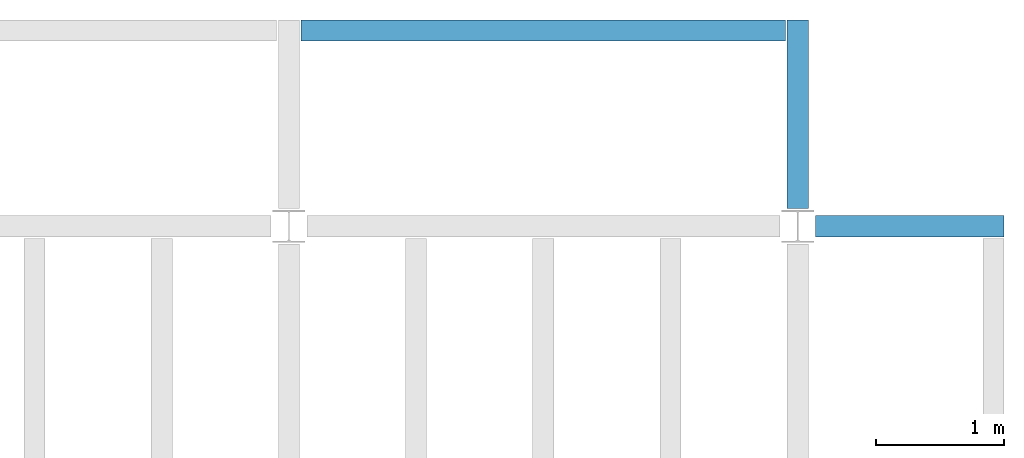
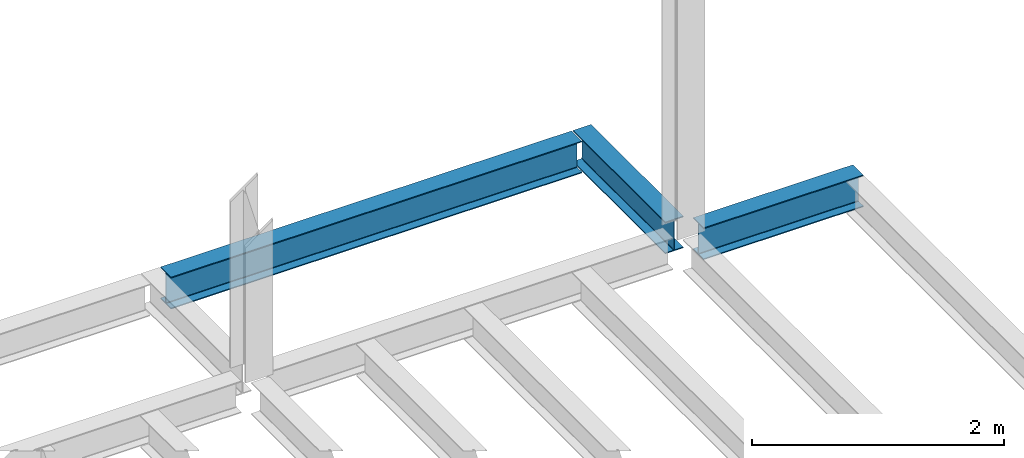
# One storey, part 3 of 3: 3 beams.
"""IFC4 building model written with IfcOpenShell, lengths in feet."""

import ifcopenshell
import ifcopenshell.guid

model = None  # the IFC model being written
_history = None  # IfcOwnerHistory: only IFC2X3 demands one
_inside = {}  # id of a spatial element -> (the spatial element, [elements in it])
_under = {}  # id of a project, library or spatial element -> (it, [spatial elements below it])
_declared = {}  # id of a project -> (the project, [libraries it declares])
_typed = {}  # id of a type object -> (the type object, [elements of that type])
_made_of = {}  # id of a material, layer set ... -> (it, [elements and type objects made of it])


def new_model(schema):
    """Start an empty IFC model of exactly this schema.

    Asked for "IFC4X3", IfcOpenShell would pick the latest addendum, in which some entities
    have other attributes; the version numbers below select the first issue.
    IFC2X3 requires an IfcOwnerHistory on every rooted entity: one is made here for all.
    """
    global model, _history
    if schema == "IFC4X3":
        model = ifcopenshell.file(schema_version=(4, 3, 0, 0))
    else:
        model = ifcopenshell.file(schema=schema)
    _inside.clear()
    _under.clear()
    _declared.clear()
    _typed.clear()
    _made_of.clear()
    _history = None
    if model.schema == "IFC2X3":
        org = make("IfcOrganization", Name="unknown")
        user = make(
            "IfcPersonAndOrganization",
            ThePerson=make("IfcPerson", FamilyName="unknown"),
            TheOrganization=org,
        )
        app = make(
            "IfcApplication",
            ApplicationDeveloper=org,
            Version="unknown",
            ApplicationFullName="unknown",
            ApplicationIdentifier="unknown",
        )
        _history = make(
            "IfcOwnerHistory",
            OwningUser=user,
            OwningApplication=app,
            ChangeAction="ADDED",
            CreationDate=0,
        )
    return model


def make(cls, **values):
    """One entity of the class cls with the attributes given. An attribute that is None is left unset."""
    return model.create_entity(
        cls, **{name: value for name, value in values.items() if value is not None}
    )


def entity(cls, *values):
    """Any entity or typed value of the class cls, its attributes in the order of the schema. None: left unset."""
    e = model.create_entity(cls)
    for i, value in enumerate(values):
        if value is not None:
            e[i] = value
    return e


def rooted(cls, **values):
    """An entity with a GlobalId (a new one), such as an element, a storey or a relation."""
    return make(cls, GlobalId=ifcopenshell.guid.new(), OwnerHistory=_history, **values)


def si_unit(unit_type, name, prefix=None):
    """IfcSIUnit, for example si_unit("LENGTHUNIT", "METRE", prefix="MILLI")."""
    return make("IfcSIUnit", UnitType=unit_type, Prefix=prefix, Name=name)


def converted_unit(unit_type, name, factor, base, dimensions=None, offset=None):
    """IfcConversionBasedUnit, such as the inch: factor (a typed value) times the base unit."""
    return make(
        "IfcConversionBasedUnit"
        if offset is None
        else "IfcConversionBasedUnitWithOffset",
        ConversionOffset=offset,
        Dimensions=None
        if dimensions is None
        else entity("IfcDimensionalExponents", *dimensions),
        UnitType=unit_type,
        Name=name,
        ConversionFactor=make(
            "IfcMeasureWithUnit", ValueComponent=factor, UnitComponent=base
        ),
    )


def derived_unit(unit_type, elements):
    """IfcDerivedUnit: a product of units, each with its exponent."""
    return make(
        "IfcDerivedUnit",
        Elements=[
            make("IfcDerivedUnitElement", Unit=unit, Exponent=power)
            for unit, power in elements
        ],
        UnitType=unit_type,
    )


def assignment(units):
    """IfcUnitAssignment: the units of a project."""
    return None if units is None else make("IfcUnitAssignment", Units=units)


def point(xyz):
    """IfcCartesianPoint."""
    return None if xyz is None else make("IfcCartesianPoint", Coordinates=xyz)


def direction(xyz):
    """IfcDirection."""
    return None if xyz is None else make("IfcDirection", DirectionRatios=xyz)


def frame(location, z_axis=None, x_axis=None):
    """IfcAxis2Placement3D, a coordinate frame: its origin and axes. An axis left out is left unset."""
    return make(
        "IfcAxis2Placement3D",
        Location=point(location),
        Axis=direction(z_axis),
        RefDirection=direction(x_axis),
    )


def origin():
    """The frame at (0, 0, 0) with its axes left unset."""
    return frame((0.0, 0.0, 0.0))


def place(relative_to, where):
    """IfcLocalPlacement: puts the frame where relative to a parent placement (None: the world)."""
    return make(
        "IfcLocalPlacement", PlacementRelTo=relative_to, RelativePlacement=where
    )


def context(
    kind, dimensions, precision=None, world=None, true_north=None, identifier=None
):
    """IfcGeometricRepresentationContext, for example the 3D "Model" context."""
    return make(
        "IfcGeometricRepresentationContext",
        ContextIdentifier=identifier,
        ContextType=kind,
        CoordinateSpaceDimension=dimensions,
        Precision=precision,
        WorldCoordinateSystem=world,
        TrueNorth=true_north,
    )


def subcontext(parent, identifier, kind, view, scale=None):
    """IfcGeometricRepresentationSubContext, for example "Body" below "Model"."""
    return make(
        "IfcGeometricRepresentationSubContext",
        ContextIdentifier=identifier,
        ContextType=kind,
        ParentContext=parent,
        TargetScale=scale,
        TargetView=view,
    )


def project(units=None, contexts=None):
    """IfcProject with its units and contexts."""
    return rooted(
        "IfcProject",
        Name="project",
        RepresentationContexts=contexts,
        UnitsInContext=assignment(units),
    )


def spatial(cls, under=None, at=None, **own):
    """A site, building, storey or space (cls), placed at a placement, below another one or the project."""
    s = rooted(cls, ObjectPlacement=at, **own)
    if under is not None:
        _under.setdefault(under.id(), (under, []))[1].append(s)
    return s


def point_list(points):
    """IfcCartesianPointList2D or 3D."""
    cls = (
        "IfcCartesianPointList2D" if len(points[0]) == 2 else "IfcCartesianPointList3D"
    )
    return make(cls, CoordList=points)


def line(*indices):
    """IfcLineIndex: a straight run through numbered points of an indexed curve."""
    return model.create_entity("IfcLineIndex", indices)


def arc(*indices):
    """IfcArcIndex: an arc through three numbered points of an indexed curve."""
    return model.create_entity("IfcArcIndex", indices)


def indexed_curve(points, segments=None, self_intersect=None):
    """IfcIndexedPolyCurve: lines and arcs through numbered points (the first is 1)."""
    return make(
        "IfcIndexedPolyCurve",
        Points=point_list(points),
        Segments=segments,
        SelfIntersect=self_intersect,
    )


def outline(outer, holes=None, kind="AREA"):
    """IfcArbitraryClosedProfileDef: a profile drawn as a closed curve; with holes, ...WithVoids."""
    if holes is None:
        return make("IfcArbitraryClosedProfileDef", ProfileType=kind, OuterCurve=outer)
    return make(
        "IfcArbitraryProfileDefWithVoids",
        ProfileType=kind,
        OuterCurve=outer,
        InnerCurves=holes,
    )


def extrude(swept, where, along, depth):
    """IfcExtrudedAreaSolid: the profile swept, set in the frame where, extruded along a direction by depth."""
    return make(
        "IfcExtrudedAreaSolid",
        SweptArea=swept,
        Position=where,
        ExtrudedDirection=direction(along),
        Depth=depth,
    )


def shape(context_of_items, identifier, shape_type, items):
    """IfcShapeRepresentation: the items that make up one representation, for example the "Body"."""
    return make(
        "IfcShapeRepresentation",
        ContextOfItems=context_of_items,
        RepresentationIdentifier=identifier,
        RepresentationType=shape_type,
        Items=items,
    )


def source(mapping_origin, context_of_items, identifier, shape_type, items):
    """IfcRepresentationMap: a shape defined once, which mapped items show again and again."""
    return make(
        "IfcRepresentationMap",
        MappingOrigin=mapping_origin,
        MappedRepresentation=shape(context_of_items, identifier, shape_type, items),
    )


def transform(
    local_origin,
    x_axis=None,
    y_axis=None,
    z_axis=None,
    scale=None,
    scale2=None,
    scale3=None,
    uniform=True,
):
    """IfcCartesianTransformationOperator3D, or its non-uniform kind. x_axis, y_axis, z_axis: its Axis1, 2, 3."""
    if uniform:
        return make(
            "IfcCartesianTransformationOperator3D",
            Axis1=direction(x_axis),
            Axis2=direction(y_axis),
            LocalOrigin=point(local_origin),
            Scale=scale,
            Axis3=direction(z_axis),
        )
    return make(
        "IfcCartesianTransformationOperator3DnonUniform",
        Axis1=direction(x_axis),
        Axis2=direction(y_axis),
        LocalOrigin=point(local_origin),
        Scale=scale,
        Axis3=direction(z_axis),
        Scale2=scale2,
        Scale3=scale3,
    )


def mapped(mapping_source, mapping_target):
    """IfcMappedItem: shows the shape of a source again, moved by a transform."""
    return make(
        "IfcMappedItem", MappingSource=mapping_source, MappingTarget=mapping_target
    )


def material(Name=None, Category=None):
    """IfcMaterial."""
    return make("IfcMaterial", Name=Name, Category=Category)


def made_of(thing, what):
    """Note that an element or type object is made of a material, layer set ...; save() writes the relation."""
    if what is not None:
        _made_of.setdefault(what.id(), (what, []))[1].append(thing)
    return thing


def type_object(cls, material=None, **own):
    """A type object (cls), such as IfcWallType, which elements share."""
    return made_of(rooted(cls, **own), material)


def type_shapes(of_type, sources):
    """Give a type object the sources (RepresentationMaps) that its elements show as mapped items."""
    of_type.RepresentationMaps = sources


def element(
    cls,
    number,
    at=None,
    inside=None,
    cuts=None,
    type_object=None,
    material=None,
    context=None,
    identifier="Body",
    shape_type=None,
    held_by="IfcProductDefinitionShape",
    body=None,
    shapes=None,
    **own,
):
    """One element of the class cls, such as IfcWall. Its Tag is "e" and its number.

    at: its placement. inside: the storey or other place that contains it. cuts: it is an
    opening in that element (IfcRelVoidsElement). A single representation is given by context,
    identifier, shape_type and body (its items); several are given by shapes. held_by: the class
    of the entity that holds the representations. save() writes the other relations.
    """
    e = rooted(cls, Tag="e%d" % number, ObjectPlacement=at, **own)
    if body is not None:
        shapes = [shape(context, identifier, shape_type, body)]
    if shapes is not None:
        e.Representation = make(held_by, Representations=shapes)
    if inside is not None:
        _inside.setdefault(inside.id(), (inside, []))[1].append(e)
    if cuts is not None:
        rooted(
            "IfcRelVoidsElement", RelatingBuildingElement=cuts, RelatedOpeningElement=e
        )
    if type_object is not None:
        _typed.setdefault(type_object.id(), (type_object, []))[1].append(e)
    return made_of(e, material)


def aggregate(whole, parts):
    """IfcRelAggregates: a whole, such as a stair, and the parts it consists of."""
    return rooted("IfcRelAggregates", RelatingObject=whole, RelatedObjects=parts)


def save(model, path):
    """Write the relations noted so far, then the file.

    IfcRelAggregates (storeys below a building ...), IfcRelContainedInSpatialStructure (elements
    in a storey), IfcRelDefinesByType, IfcRelAssociatesMaterial and IfcRelDeclares: one each for
    every whole, place, type object, material and project.
    """
    for whole, parts in _under.values():
        aggregate(whole, parts)
    for where, things in _inside.values():
        rooted(
            "IfcRelContainedInSpatialStructure",
            RelatedElements=things,
            RelatingStructure=where,
        )
    for kind, things in _typed.values():
        rooted("IfcRelDefinesByType", RelatedObjects=things, RelatingType=kind)
    for what, things in _made_of.values():
        rooted("IfcRelAssociatesMaterial", RelatedObjects=things, RelatingMaterial=what)
    for by, libraries in _declared.values():
        rooted("IfcRelDeclares", RelatingContext=by, RelatedDefinitions=libraries)
    model.write(path)


model = new_model("IFC4")

# Units and contexts
model_context = context("Model", 3, precision=0.0001, world=origin(), true_north=direction((6.123233995736766e-17, 1.0)))
plan_context = context("Plan", 3, precision=0.0001, world=origin(), true_north=direction((6.123233995736766e-17, 1.0)))
body_context = subcontext(model_context, "Body", "Model", "MODEL_VIEW")
ifc_project = project(units=[converted_unit("LENGTHUNIT", "FOOT", entity("IfcLengthMeasure", 0.3048), si_unit("LENGTHUNIT", "METRE"), dimensions=[1, 0, 0, 0, 0, 0, 0]), converted_unit("AREAUNIT", "SQUARE FOOT", entity("IfcAreaMeasure", 0.09290304), si_unit("AREAUNIT", "SQUARE_METRE"), dimensions=[2, 0, 0, 0, 0, 0, 0]), converted_unit("PLANEANGLEUNIT", "DEGREE", entity("IfcPlaneAngleMeasure", 0.017453292519943278), si_unit("PLANEANGLEUNIT", "RADIAN"), dimensions=[0, 0, 0, 0, 0, 0, 0]), converted_unit("VOLUMEUNIT", "CUBIC FOOT", entity("IfcVolumeMeasure", 0.028316846592000004), si_unit("VOLUMEUNIT", "CUBIC_METRE"), dimensions=[3, 0, 0, 0, 0, 0, 0]), si_unit("PRESSUREUNIT", "PASCAL"), derived_unit("MASSDENSITYUNIT", [(si_unit("MASSUNIT", "GRAM", prefix="KILO"), 1), (si_unit("LENGTHUNIT", "METRE"), -3)]), derived_unit("VAPORPERMEABILITYUNIT", [(si_unit("LENGTHUNIT", "METRE"), -1), (si_unit("TIMEUNIT", "SECOND"), 1)]), derived_unit("USERDEFINED", [(si_unit("MASSUNIT", "GRAM", prefix="KILO"), 1), (si_unit("LENGTHUNIT", "METRE"), 3), (si_unit("TIMEUNIT", "SECOND"), -3), (si_unit("ELECTRICCURRENTUNIT", "AMPERE"), -2)]), derived_unit("MODULUSOFELASTICITYUNIT", [(si_unit("MASSUNIT", "GRAM", prefix="KILO"), 1), (si_unit("LENGTHUNIT", "METRE"), -1), (si_unit("TIMEUNIT", "SECOND"), -2)]), derived_unit("THERMALEXPANSIONCOEFFICIENTUNIT", [(si_unit("THERMODYNAMICTEMPERATUREUNIT", "KELVIN"), -1)]), derived_unit("SPECIFICHEATCAPACITYUNIT", [(si_unit("TIMEUNIT", "SECOND"), -2), (si_unit("THERMODYNAMICTEMPERATUREUNIT", "KELVIN"), -1), (si_unit("LENGTHUNIT", "METRE"), 2)]), derived_unit("THERMALCONDUCTANCEUNIT", [(si_unit("MASSUNIT", "GRAM", prefix="KILO"), 1), (si_unit("TIMEUNIT", "SECOND"), -3), (si_unit("THERMODYNAMICTEMPERATUREUNIT", "KELVIN"), -1), (si_unit("LENGTHUNIT", "METRE"), 1)])], contexts=[model_context, plan_context])

# Site, building, storey
site_placement = place(None, origin())
site = spatial("IfcSite", under=ifc_project, at=site_placement, CompositionType="ELEMENT")
building_placement = place(site_placement, origin())
building = spatial("IfcBuilding", under=site, at=building_placement, CompositionType="ELEMENT")
storey_placement = place(building_placement, frame((0.0, 0.0, 119.875)))
storey = spatial("IfcBuildingStorey", under=building, at=storey_placement, Name="STR 13", CompositionType="ELEMENT", Elevation=119.875)

# Beams
ifc_material = material(Name="Steel ASTM A992", Category="Metal")
beam_type_1 = type_object("IfcBeamType", Name="W12X26", PredefinedType="JOIST", material=ifc_material)
shared_shape_1 = source(origin(), body_context, "Body", "SweptSolid", [
    extrude(outline(indexed_curve([(0.47666666666666574, -0.2704166666666672), (0.5083333333333351, -0.2704166666666672), (0.5083333333333351, 0.27041666666666686), (0.47666666666666574, 0.27041666666666686), (0.47666666666666574, 0.03458333333333307), (0.46934433619632937, 0.016905663803669473), (0.4516666666666659, 0.00958333333333318), (-0.45166666666666705, 0.00958333333333318), (-0.4693443361963307, 0.01690566380366946), (-0.4766666666666671, 0.03458333333333323), (-0.4766666666666671, 0.27041666666666686), (-0.5083333333333312, 0.27041666666666686), (-0.5083333333333312, -0.27041666666666553), (-0.4766666666666671, -0.27041666666666553), (-0.47666666666666707, -0.034583333333333535), (-0.46934433619633054, -0.016905663803669885), (-0.45166666666666694, -0.00958333333333376), (0.4516666666666658, -0.009583333333333756), (0.4693443361963295, -0.01690566380367015), (0.47666666666666574, -0.0345833333333337)], segments=[line(1, 2, 3, 4, 5), arc(5, 6, 7), line(7, 8), arc(8, 9, 10), line(10, 11, 12, 13, 14, 15), arc(15, 16, 17), line(17, 18), arc(18, 19, 20), line(20, 1)], self_intersect=False)), frame((-2.77041666666672, 0.0, 0.0), z_axis=(1.0, 0.0, 0.0), x_axis=(0.0, 0.0, -1.0)), (0.0, 0.0, 1.0), 4.812083333333389),
])
type_shapes(beam_type_1, [shared_shape_1])
beam_1_placement = place(storey_placement, frame((41.50000000000015, 39.0, -0.50833333333334), z_axis=(0.0, 0.0, 1.0), x_axis=(-1.0, 0.0, 0.0)))
element("IfcBeam", 1, at=beam_1_placement, inside=storey, type_object=beam_type_1, material=ifc_material, Name="W12X26", ObjectType="W Shapes:W12X26", PredefinedType="JOIST", context=body_context, shape_type="MappedRepresentation", body=[
    mapped(shared_shape_1, transform((0.0, 0.0, 0.0), scale=1.0)),
])
beam_type_2 = type_object("IfcBeamType", Name="W12X26", PredefinedType="JOIST", material=ifc_material)
shared_shape_2 = source(origin(), body_context, "Body", "SweptSolid", [
    extrude(outline(indexed_curve([(-0.2704166666666623, -0.50833333333334), (0.2704166666666694, -0.50833333333334), (0.2704166666666694, -0.4766666666666737), (0.03458333333333741, -0.4766666666666879), (0.01690566380367642, -0.4693443361963432), (0.009583333333338828, -0.4516666666666822), (0.009583333333338828, 0.4516666666666538), (0.01690566380367642, 0.46934433619631477), (0.03458333333333741, 0.47666666666665947), (0.2704166666666694, 0.47666666666665947), (0.2704166666666694, 0.5083333333333258), (-0.2704166666666623, 0.5083333333333258), (-0.2704166666666623, 0.47666666666665947), (-0.0345833333333303, 0.47666666666665947), (-0.016905663803669313, 0.46934433619631477), (-0.009583333333331723, 0.4516666666666538), (-0.009583333333331723, -0.4516666666666822), (-0.016905663803669313, -0.4693443361963432), (-0.0345833333333303, -0.4766666666666737), (-0.2704166666666623, -0.4766666666666737)], segments=[line(1, 2, 3, 4), arc(4, 5, 6), line(6, 7), arc(7, 8, 9), line(9, 10, 11, 12, 13, 14), arc(14, 15, 16), line(16, 17), arc(17, 18, 19), line(19, 20, 1)], self_intersect=False)), frame((39.0, 44.270416666666286, 119.36666666666663), z_axis=(0.0, -1.0, 0.0), x_axis=(-1.0, 0.0, 0.0)), (0.0, 0.0, 1.0), 4.812083333333393),
])
type_shapes(beam_type_2, [shared_shape_2])
beam_2_placement = place(storey_placement, frame((0.0, 0.0, -119.875)))
element("IfcBeam", 2, at=beam_2_placement, inside=storey, type_object=beam_type_2, material=ifc_material, Name="W12X26", ObjectType="W Shapes:W12X26", PredefinedType="JOIST", context=body_context, shape_type="MappedRepresentation", body=[
    mapped(shared_shape_2, transform((0.0, 0.0, 0.0), scale=1.0)),
])
beam_type_3 = type_object("IfcBeamType", Name="W12X26", PredefinedType="JOIST", material=ifc_material)
shared_shape_3 = source(origin(), body_context, "Body", "SweptSolid", [
    extrude(outline(indexed_curve([(-0.50833333333334, -0.2704166666666694), (-0.4766666666666737, -0.2704166666666694), (-0.4766666666666879, -0.03458333333333741), (-0.4693443361963432, -0.01690566380367642), (-0.4516666666666822, -0.009583333333338828), (0.4516666666666538, -0.009583333333338828), (0.46934433619631477, -0.01690566380367642), (0.47666666666665947, -0.03458333333333741), (0.47666666666665947, -0.2704166666666694), (0.5083333333333258, -0.2704166666666694), (0.5083333333333258, 0.2704166666666623), (0.47666666666665947, 0.2704166666666623), (0.47666666666665947, 0.0345833333333303), (0.46934433619631477, 0.016905663803669313), (0.4516666666666538, 0.009583333333331723), (-0.4516666666666822, 0.009583333333331723), (-0.4693443361963432, 0.016905663803669313), (-0.4766666666666737, 0.0345833333333303), (-0.4766666666666737, 0.2704166666666623), (-0.50833333333334, 0.2704166666666623)], segments=[line(1, 2, 3), arc(3, 4, 5), line(5, 6), arc(6, 7, 8), line(8, 9, 10, 11, 12, 13), arc(13, 14, 15), line(15, 16), arc(16, 17, 18), line(18, 19, 20, 1)], self_intersect=False)), frame((26.312083333333604, 44.0, 119.36666666666663), z_axis=(1.0, 0.0, 0.0), x_axis=(0.0, 0.0, -1.0)), (0.0, 0.0, 1.0), 12.375833333333079),
])
type_shapes(beam_type_3, [shared_shape_3])
beam_3_placement = place(storey_placement, frame((0.0, 0.0, -119.875)))
element("IfcBeam", 3, at=beam_3_placement, inside=storey, type_object=beam_type_3, material=ifc_material, Name="W Shapes:W12X26", ObjectType="W Shapes:W12X26", PredefinedType="JOIST", context=body_context, shape_type="MappedRepresentation", body=[
    mapped(shared_shape_3, transform((0.0, 0.0, 0.0), scale=1.0)),
])

save(model, "model.ifc")
